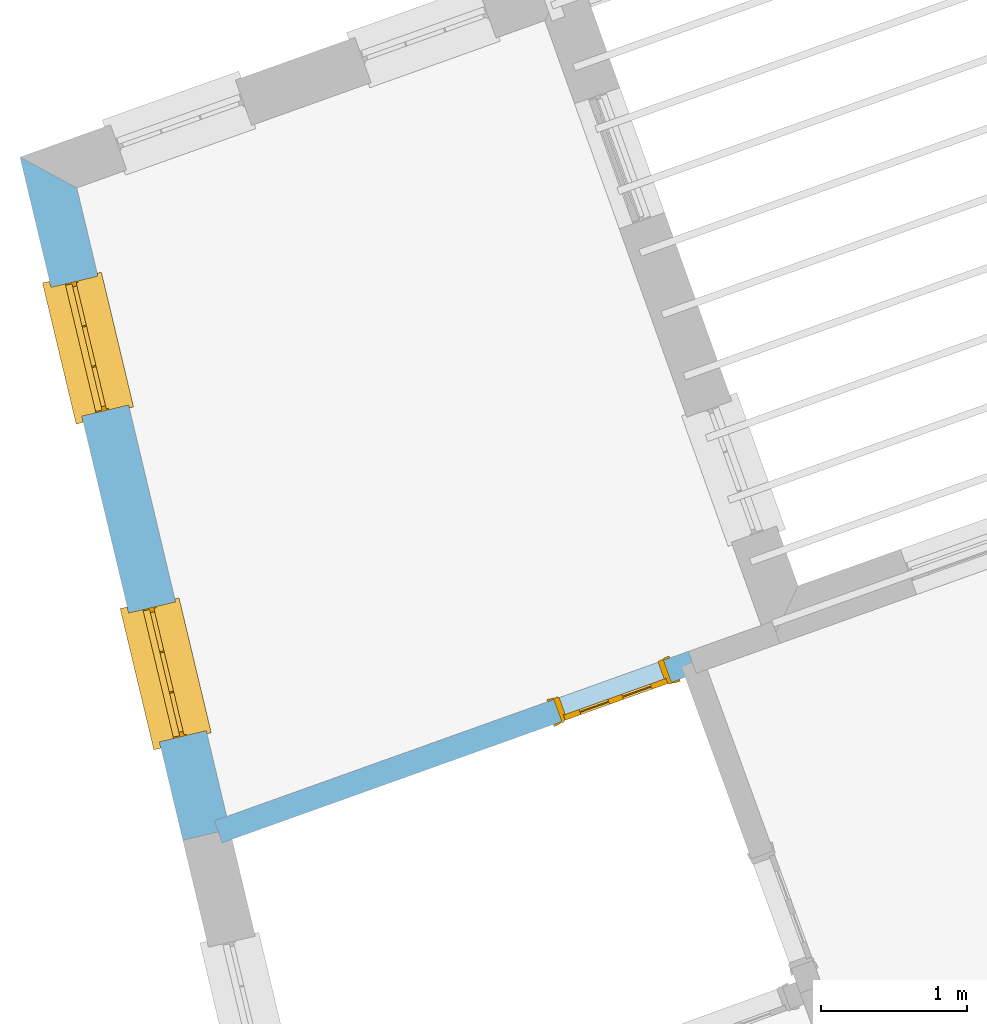
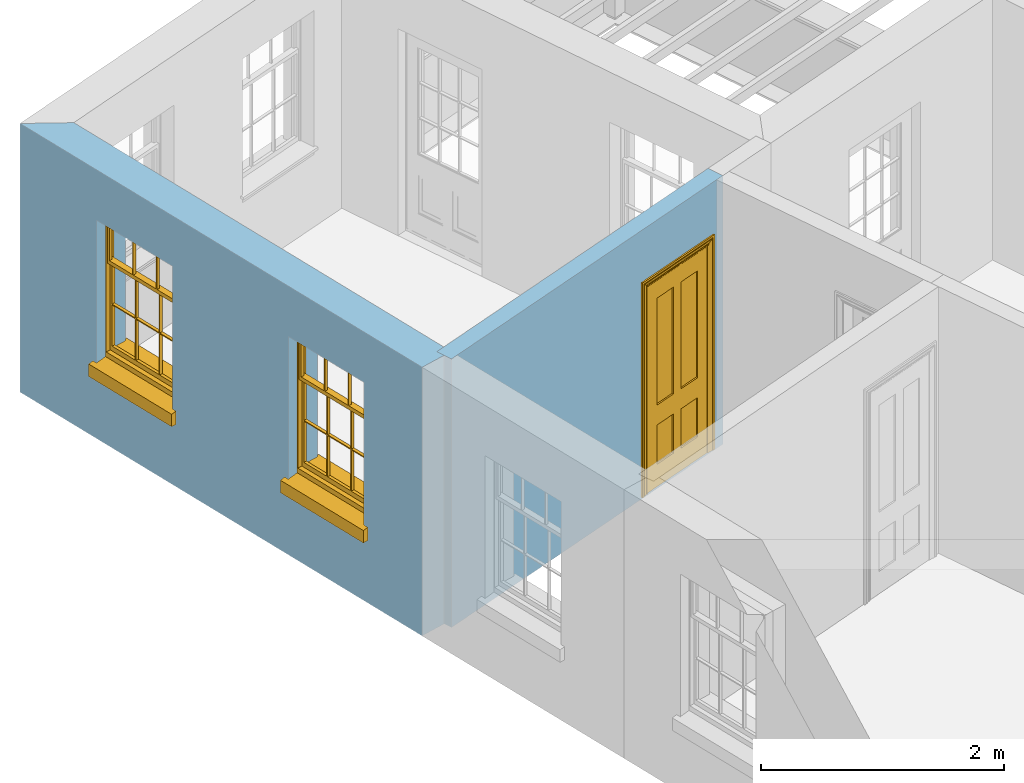
# One storey, part 8 of 12: 2 windows, 1 door, 3 openings, plus 2 elements that do not belong to this part.
"""IFC2X3 building model written with IfcOpenShell, lengths in metres."""

from ifc_helpers import new_model, si_unit, frame, origin, place, context, subcontext, project, spatial, polyline, outline, extrude, faceted_brep, material, layer, layer_set, layer_usage, element, fill, save


model = new_model("IFC2X3")

# Units and contexts
model_context = context("Model", 3, world=origin())
body_context = subcontext(model_context, "Body", "Model", "MODEL_VIEW")
ifc_project = project(units=[si_unit("PLANEANGLEUNIT", "RADIAN"), si_unit("MASSUNIT", "GRAM", prefix="KILO"), si_unit("FORCEUNIT", "NEWTON", prefix="KILO"), si_unit("LENGTHUNIT", "METRE")], contexts=[model_context])

# Site, building, storey
site_placement = place(None, origin())
site = spatial("IfcSite", under=ifc_project, at=site_placement, CompositionType="ELEMENT")
building_placement = place(None, origin())
building = spatial("IfcBuilding", under=site, at=building_placement, Name="Building plot-12", CompositionType="ELEMENT")
storey_placement = place(None, frame((0.0, 0.0, 6.45)))
storey = spatial("IfcBuildingStorey", under=building, at=storey_placement, Name="Floor 1", CompositionType="ELEMENT", Elevation=6.45)

# Wall, openings, windows
ifc_material_1 = material(Name="Masonry")
ifc_layer_1 = layer(ifc_material_1, 0.33, ventilated=False)
ifc_layer_set_1 = layer_set([ifc_layer_1], Name="My Wall")
ifc_layer_usage_1 = layer_usage(ifc_layer_set_1, "AXIS2", "NEGATIVE", 0.08)
wall_1_placement = place(storey_placement, origin())
wall_1 = element("IfcWallStandardCase", 1, at=wall_1_placement, inside=storey, material=ifc_layer_usage_1, Name="exterior", context=body_context, shape_type="SweptSolid", body=[
    extrude(outline(polyline([(53.1438565991735, 42.9766000900277), (52.7542538663581, 43.1877513545865), (53.8716114947725, 38.5019523700673), (54.1926114220858, 38.578496779823), (53.1438565991735, 42.9766000900277)])), origin(), (0.0, 0.0, 1.0), 2.7),
])
opening_1_placement = place(storey_placement, frame((0.0, 0.0, 0.75)))
opening_1 = element("IfcOpeningElement", 2, at=opening_1_placement, cuts=wall_1, Name="Opening", ObjectType="Opening", context=body_context, shape_type="SweptSolid", body=[
    extrude(outline(polyline([(52.9670336358641, 42.295428966013), (53.1781106445844, 41.4102473482703), (53.4991105718977, 41.486791758026), (53.2880335631774, 42.3719733757687), (52.9670336358641, 42.295428966013)])), origin(), (0.0, 0.0, 1.0), 1.445),
])
opening_2_placement = place(storey_placement, frame((0.0, 0.0, 0.75)))
opening_2 = element("IfcOpeningElement", 3, at=opening_2_placement, cuts=wall_1, Name="Opening", ObjectType="Opening", context=body_context, shape_type="SweptSolid", body=[
    extrude(outline(polyline([(53.4997265388962, 40.0615051079635), (53.7108035476165, 39.1763234902207), (54.0318034749299, 39.2528678999764), (53.8207264662095, 40.1380495177192), (53.4997265388962, 40.0615051079635)])), origin(), (0.0, 0.0, 1.0), 1.445),
])
window_1_placement = place(storey_placement, frame((53.2102153989802, 42.3534171552219, 0.75), z_axis=(0.0, 0.0, 1.0), x_axis=(0.211077008720331, -0.885181617742759, 0.0)))
window_1 = element("IfcWindow", 4, at=window_1_placement, inside=storey, Name="bedroom outside window", OverallHeight=1.445, OverallWidth=0.91, context=body_context, shape_type="Brep", held_by="IfcProductRepresentation", body=[
    faceted_brep([(0.876875, -0.105, 0.999097), (0.876875, -0.105, 1.411875), (0.9, -0.105, 1.435), (0.033125, -0.105, 1.411875), (0.033125, -0.105, 0.999097), (0.01, -0.105, 1.435), (0.033125, -0.135, 1.411875), (0.01, -0.135, 1.435), (0.033125, -0.135, 0.999097), (0.876875, -0.135, 1.411875), (0.876875, -0.135, 0.999097), (0.9, -0.135, 1.435), (0.033125, -0.105, 0.960972), (0.01, -0.105, 0.960972), (0.033125, -0.105, 0.548195), (0.876875, -0.105, 0.960972), (0.876875, -0.105, 0.548195), (0.9, -0.105, 0.960972), (0.876875, -0.105, 0.538195), (0.876875, -0.105, 0.125417), (0.9, -0.105, 0.077167), (0.033125, -0.105, 0.125417), (0.033125, -0.105, 0.538195), (0.01, -0.105, 0.077167), (0.9, -0.135, 0.960972), (0.01, -0.135, 0.960972), (-0.0425, -0.25, 0.01), (-0.0425, -0.3, 0.001667), (0.0, -0.25, 0.01), (0.9525, -0.25, 0.01), (0.91, -0.25, 0.01), (0.9525, -0.3, 0.001667), (-0.02, 0.08, 0.077167), (0.0, 0.08, 0.077167), (-0.02, 0.11, 0.077167), (0.0, -0.06, 0.077167), (0.01, -0.06, 0.077167), (0.91, -0.06, 0.077167), (0.91, 0.08, 0.077167), (0.9, -0.06, 0.077167), (0.93, 0.08, 0.077167), (0.93, 0.11, 0.077167), (0.01, -0.105, 0.999097), (0.01, -0.075, 0.999097), (0.9, -0.105, 0.999097), (0.9, -0.075, 0.999097), (0.876875, -0.075, 0.125417), (0.876875, -0.075, 0.538195), (0.9, -0.075, 0.077167), (0.876875, -0.075, 0.548195), (0.876875, -0.075, 0.960972), (0.033125, -0.075, 0.125417), (0.01, -0.075, 0.077167), (0.033125, -0.075, 0.538195), (0.033125, -0.075, 0.960972), (0.033125, -0.075, 0.548195), (-0.02, 0.08, 0.052167), (-0.02, 0.11, 0.052167), (0.93, 0.11, 0.052167), (0.93, 0.08, 0.052167), (0.91, 0.08, 0.052167), (0.0, 0.08, 0.052167), (0.91, -0.15, 0.026667), (0.0, -0.15, 0.026667), (-0.0425, -0.3, -0.123333), (0.9525, -0.3, -0.123333), (-0.0425, -0.25, -0.123333), (0.9525, -0.25, -0.123333), (0.01, -0.06, 1.435), (0.9, -0.06, 1.435), (0.0, -0.06, 1.445), (0.91, -0.06, 1.445), (0.01, -0.15, 0.077167), (0.9, -0.15, 0.077167), (0.592292, -0.105, 0.125417), (0.592292, -0.075, 0.125417), (0.317708, -0.075, 0.125417), (0.317708, -0.105, 0.125417), (0.592292, -0.105, 0.548195), (0.317708, -0.105, 0.548195), (0.317708, -0.105, 0.538195), (0.592292, -0.105, 0.538195), (0.592292, -0.075, 0.548195), (0.317708, -0.075, 0.548195), (0.602292, -0.075, 0.548195), (0.602292, -0.105, 0.548195), (0.317708, -0.075, 0.538195), (0.307708, -0.075, 0.125417), (0.307708, -0.075, 0.538195), (0.602292, -0.075, 0.538195), (0.602292, -0.075, 0.125417), (0.592292, -0.075, 0.538195), (0.307708, -0.075, 0.548195), (0.317708, -0.075, 0.960972), (0.307708, -0.075, 0.960972), (0.602292, -0.075, 0.960972), (0.592292, -0.075, 0.960972), (0.307708, -0.105, 0.538195), (0.307708, -0.105, 0.125417), (0.307708, -0.105, 0.548195), (0.307708, -0.105, 0.960972), (0.592292, -0.105, 0.960972), (0.317708, -0.105, 0.960972), (0.602292, -0.105, 0.960972), (0.602292, -0.105, 0.538195), (0.602292, -0.105, 0.125417), (0.317708, -0.135, 1.411875), (0.307708, -0.135, 1.411875), (0.307708, -0.135, 0.999097), (0.317708, -0.135, 0.999097), (0.602292, -0.135, 1.411875), (0.592292, -0.135, 1.411875), (0.592292, -0.135, 0.999097), (0.602292, -0.135, 0.999097), (0.317708, -0.105, 0.999097), (0.307708, -0.105, 0.999097), (0.307708, -0.105, 1.411875), (0.317708, -0.105, 1.411875), (0.602292, -0.105, 0.999097), (0.592292, -0.105, 0.999097), (0.592292, -0.105, 1.411875), (0.602292, -0.105, 1.411875), (0.91, -0.15, 1.445), (0.9, -0.15, 1.435), (0.01, -0.15, 1.435), (0.0, -0.15, 1.445), (0.91, -0.25, 0.0), (0.0, -0.25, 0.0), (0.91, 0.08, 0.0), (0.0, 0.08, 0.0)], [[[0, 1, 2]], [[3, 4, 5]], [[6, 7, 8]], [[9, 10, 11]], [[12, 13, 14]], [[15, 16, 17]], [[18, 19, 20]], [[21, 22, 23]], [[24, 15, 17]], [[13, 12, 25]], [[26, 27, 28]], [[29, 30, 31]], [[32, 33, 34]], [[35, 36, 33]], [[37, 38, 39]], [[40, 41, 38]], [[42, 4, 43]], [[44, 45, 0]], [[46, 47, 48]], [[49, 50, 45]], [[51, 52, 53]], [[54, 55, 43]], [[38, 33, 36, 39]], [[41, 34, 33, 38]], [[56, 32, 34, 57]], [[57, 34, 41, 58]], [[58, 41, 40, 59]], [[57, 58, 60, 61]], [[52, 48, 39, 36]], [[62, 63, 28, 30]], [[27, 31, 30, 28]], [[27, 64, 65, 31]], [[66, 67, 65, 64]], [[2, 5, 68, 69]], [[68, 70, 71, 69]], [[20, 23, 72, 73]], [[73, 72, 63, 62]], [[74, 75, 76, 77]], [[78, 79, 80, 81]], [[78, 82, 83, 79]], [[16, 49, 84, 85]], [[86, 76, 87, 88]], [[89, 90, 75, 91]], [[92, 88, 53, 55]], [[82, 91, 86, 83]], [[93, 83, 92, 94]], [[95, 84, 82, 96]], [[89, 84, 49, 47]], [[97, 88, 87, 98]], [[22, 53, 88, 97]], [[81, 91, 75, 74]], [[80, 86, 91, 81]], [[77, 76, 86, 80]], [[99, 92, 55, 14]], [[100, 94, 92, 99]], [[101, 96, 82, 78]], [[79, 83, 93, 102]], [[85, 84, 95, 103]], [[104, 89, 47, 18]], [[105, 90, 89, 104]], [[104, 18, 16, 85]], [[80, 97, 98, 77]], [[104, 81, 74, 105]], [[103, 101, 78, 85]], [[99, 14, 22, 97]], [[102, 100, 99, 79]], [[106, 107, 108, 109]], [[110, 111, 112, 113]], [[114, 115, 116, 117]], [[118, 119, 120, 121]], [[107, 116, 115, 108]], [[111, 120, 119, 112]], [[109, 114, 117, 106]], [[113, 118, 121, 110]], [[85, 78, 81, 104]], [[84, 89, 91, 82]], [[83, 86, 88, 92]], [[79, 99, 97, 80]], [[109, 112, 119, 114]], [[102, 93, 96, 101]], [[106, 117, 120, 111]], [[98, 87, 51, 21]], [[6, 3, 116, 107]], [[110, 121, 1, 9]], [[19, 46, 90, 105]], [[26, 66, 64, 27]], [[29, 31, 65, 67]], [[25, 24, 112, 109]], [[11, 7, 106, 111]], [[75, 48, 52, 76]], [[43, 45, 96, 93]], [[45, 43, 114, 119]], [[5, 2, 120, 117]], [[24, 25, 102, 101]], [[42, 5, 4]], [[2, 44, 0]], [[49, 45, 48, 47]], [[52, 43, 55, 53]], [[14, 13, 23, 22]], [[20, 17, 16, 18]], [[24, 11, 10]], [[25, 8, 7]], [[8, 4, 3, 6]], [[9, 1, 0, 10]], [[15, 50, 49, 16]], [[18, 47, 46, 19]], [[21, 51, 53, 22]], [[14, 55, 54, 12]], [[44, 2, 69, 45]], [[68, 5, 42, 43]], [[36, 35, 70, 68]], [[39, 69, 71, 37]], [[62, 122, 123, 73]], [[63, 72, 124, 125]], [[8, 108, 115, 4]], [[113, 10, 0, 118]], [[94, 100, 12, 54]], [[17, 20, 73, 24]], [[72, 23, 13, 25]], [[52, 36, 68, 43]], [[69, 39, 48, 45]], [[11, 24, 73, 123]], [[7, 124, 72, 25]], [[23, 77, 98]], [[98, 21, 23]], [[105, 74, 20]], [[20, 19, 105]], [[20, 74, 77, 23]], [[113, 112, 24]], [[24, 10, 113]], [[25, 109, 108]], [[108, 8, 25]], [[110, 9, 11]], [[11, 111, 110]], [[7, 6, 107]], [[107, 106, 7]], [[5, 117, 116]], [[116, 3, 5]], [[121, 120, 2]], [[2, 1, 121]], [[11, 123, 124, 7]], [[122, 125, 124, 123]], [[43, 93, 94]], [[94, 54, 43]], [[96, 45, 95]], [[50, 95, 45]], [[15, 103, 95, 50]], [[48, 75, 90]], [[90, 46, 48]], [[87, 76, 52]], [[52, 51, 87]], [[103, 15, 24]], [[24, 101, 103]], [[100, 102, 25]], [[25, 12, 100]], [[115, 114, 43]], [[43, 4, 115]], [[118, 0, 45]], [[45, 119, 118]], [[71, 70, 125, 122]], [[70, 35, 63, 125]], [[122, 62, 37, 71]], [[126, 67, 66, 127]], [[60, 58, 59]], [[38, 60, 59, 40]], [[61, 56, 57]], [[32, 56, 61, 33]], [[61, 60, 128, 129]], [[62, 60, 38, 37]], [[126, 128, 60, 62]], [[33, 61, 63, 35]], [[61, 129, 127, 63]], [[128, 126, 127, 129]], [[28, 127, 66, 26]], [[63, 127, 28]], [[29, 67, 126, 30]], [[30, 126, 62]]]),
])
fill(opening_1, window_1)
window_2_placement = place(storey_placement, frame((53.7429083020124, 40.1194932971724, 0.75), z_axis=(0.0, 0.0, 1.0), x_axis=(0.211077008720331, -0.885181617742759, 0.0)))
window_2 = element("IfcWindow", 5, at=window_2_placement, inside=storey, Name="bedroom outside window", OverallHeight=1.445, OverallWidth=0.91, context=body_context, shape_type="Brep", held_by="IfcProductRepresentation", body=[
    faceted_brep([(0.876875, -0.105, 0.999097), (0.876875, -0.105, 1.411875), (0.9, -0.105, 1.435), (0.033125, -0.105, 1.411875), (0.033125, -0.105, 0.999097), (0.01, -0.105, 1.435), (0.033125, -0.135, 1.411875), (0.01, -0.135, 1.435), (0.033125, -0.135, 0.999097), (0.876875, -0.135, 1.411875), (0.876875, -0.135, 0.999097), (0.9, -0.135, 1.435), (0.033125, -0.105, 0.960972), (0.01, -0.105, 0.960972), (0.033125, -0.105, 0.548195), (0.876875, -0.105, 0.960972), (0.876875, -0.105, 0.548195), (0.9, -0.105, 0.960972), (0.876875, -0.105, 0.538195), (0.876875, -0.105, 0.125417), (0.9, -0.105, 0.077167), (0.033125, -0.105, 0.125417), (0.033125, -0.105, 0.538195), (0.01, -0.105, 0.077167), (0.9, -0.135, 0.960972), (0.01, -0.135, 0.960972), (-0.0425, -0.25, 0.01), (-0.0425, -0.3, 0.001667), (0.0, -0.25, 0.01), (0.9525, -0.25, 0.01), (0.91, -0.25, 0.01), (0.9525, -0.3, 0.001667), (-0.02, 0.08, 0.077167), (0.0, 0.08, 0.077167), (-0.02, 0.11, 0.077167), (0.0, -0.06, 0.077167), (0.01, -0.06, 0.077167), (0.91, -0.06, 0.077167), (0.91, 0.08, 0.077167), (0.9, -0.06, 0.077167), (0.93, 0.08, 0.077167), (0.93, 0.11, 0.077167), (0.01, -0.105, 0.999097), (0.01, -0.075, 0.999097), (0.9, -0.105, 0.999097), (0.9, -0.075, 0.999097), (0.876875, -0.075, 0.125417), (0.876875, -0.075, 0.538195), (0.9, -0.075, 0.077167), (0.876875, -0.075, 0.548195), (0.876875, -0.075, 0.960972), (0.033125, -0.075, 0.125417), (0.01, -0.075, 0.077167), (0.033125, -0.075, 0.538195), (0.033125, -0.075, 0.960972), (0.033125, -0.075, 0.548195), (-0.02, 0.08, 0.052167), (-0.02, 0.11, 0.052167), (0.93, 0.11, 0.052167), (0.93, 0.08, 0.052167), (0.91, 0.08, 0.052167), (0.0, 0.08, 0.052167), (0.91, -0.15, 0.026667), (0.0, -0.15, 0.026667), (-0.0425, -0.3, -0.123333), (0.9525, -0.3, -0.123333), (-0.0425, -0.25, -0.123333), (0.9525, -0.25, -0.123333), (0.01, -0.06, 1.435), (0.9, -0.06, 1.435), (0.0, -0.06, 1.445), (0.91, -0.06, 1.445), (0.01, -0.15, 0.077167), (0.9, -0.15, 0.077167), (0.592292, -0.105, 0.125417), (0.592292, -0.075, 0.125417), (0.317708, -0.075, 0.125417), (0.317708, -0.105, 0.125417), (0.592292, -0.105, 0.548195), (0.317708, -0.105, 0.548195), (0.317708, -0.105, 0.538195), (0.592292, -0.105, 0.538195), (0.592292, -0.075, 0.548195), (0.317708, -0.075, 0.548195), (0.602292, -0.075, 0.548195), (0.602292, -0.105, 0.548195), (0.317708, -0.075, 0.538195), (0.307708, -0.075, 0.125417), (0.307708, -0.075, 0.538195), (0.602292, -0.075, 0.538195), (0.602292, -0.075, 0.125417), (0.592292, -0.075, 0.538195), (0.307708, -0.075, 0.548195), (0.317708, -0.075, 0.960972), (0.307708, -0.075, 0.960972), (0.602292, -0.075, 0.960972), (0.592292, -0.075, 0.960972), (0.307708, -0.105, 0.538195), (0.307708, -0.105, 0.125417), (0.307708, -0.105, 0.548195), (0.307708, -0.105, 0.960972), (0.592292, -0.105, 0.960972), (0.317708, -0.105, 0.960972), (0.602292, -0.105, 0.960972), (0.602292, -0.105, 0.538195), (0.602292, -0.105, 0.125417), (0.317708, -0.135, 1.411875), (0.307708, -0.135, 1.411875), (0.307708, -0.135, 0.999097), (0.317708, -0.135, 0.999097), (0.602292, -0.135, 1.411875), (0.592292, -0.135, 1.411875), (0.592292, -0.135, 0.999097), (0.602292, -0.135, 0.999097), (0.317708, -0.105, 0.999097), (0.307708, -0.105, 0.999097), (0.307708, -0.105, 1.411875), (0.317708, -0.105, 1.411875), (0.602292, -0.105, 0.999097), (0.592292, -0.105, 0.999097), (0.592292, -0.105, 1.411875), (0.602292, -0.105, 1.411875), (0.91, -0.15, 1.445), (0.9, -0.15, 1.435), (0.01, -0.15, 1.435), (0.0, -0.15, 1.445), (0.91, -0.25, 0.0), (0.0, -0.25, 0.0), (0.91, 0.08, 0.0), (0.0, 0.08, 0.0)], [[[0, 1, 2]], [[3, 4, 5]], [[6, 7, 8]], [[9, 10, 11]], [[12, 13, 14]], [[15, 16, 17]], [[18, 19, 20]], [[21, 22, 23]], [[24, 15, 17]], [[13, 12, 25]], [[26, 27, 28]], [[29, 30, 31]], [[32, 33, 34]], [[35, 36, 33]], [[37, 38, 39]], [[40, 41, 38]], [[42, 4, 43]], [[44, 45, 0]], [[46, 47, 48]], [[49, 50, 45]], [[51, 52, 53]], [[54, 55, 43]], [[38, 33, 36, 39]], [[41, 34, 33, 38]], [[56, 32, 34, 57]], [[57, 34, 41, 58]], [[58, 41, 40, 59]], [[57, 58, 60, 61]], [[52, 48, 39, 36]], [[62, 63, 28, 30]], [[27, 31, 30, 28]], [[27, 64, 65, 31]], [[66, 67, 65, 64]], [[2, 5, 68, 69]], [[68, 70, 71, 69]], [[20, 23, 72, 73]], [[73, 72, 63, 62]], [[74, 75, 76, 77]], [[78, 79, 80, 81]], [[78, 82, 83, 79]], [[16, 49, 84, 85]], [[86, 76, 87, 88]], [[89, 90, 75, 91]], [[92, 88, 53, 55]], [[82, 91, 86, 83]], [[93, 83, 92, 94]], [[95, 84, 82, 96]], [[89, 84, 49, 47]], [[97, 88, 87, 98]], [[22, 53, 88, 97]], [[81, 91, 75, 74]], [[80, 86, 91, 81]], [[77, 76, 86, 80]], [[99, 92, 55, 14]], [[100, 94, 92, 99]], [[101, 96, 82, 78]], [[79, 83, 93, 102]], [[85, 84, 95, 103]], [[104, 89, 47, 18]], [[105, 90, 89, 104]], [[104, 18, 16, 85]], [[80, 97, 98, 77]], [[104, 81, 74, 105]], [[103, 101, 78, 85]], [[99, 14, 22, 97]], [[102, 100, 99, 79]], [[106, 107, 108, 109]], [[110, 111, 112, 113]], [[114, 115, 116, 117]], [[118, 119, 120, 121]], [[107, 116, 115, 108]], [[111, 120, 119, 112]], [[109, 114, 117, 106]], [[113, 118, 121, 110]], [[85, 78, 81, 104]], [[84, 89, 91, 82]], [[83, 86, 88, 92]], [[79, 99, 97, 80]], [[109, 112, 119, 114]], [[102, 93, 96, 101]], [[106, 117, 120, 111]], [[98, 87, 51, 21]], [[6, 3, 116, 107]], [[110, 121, 1, 9]], [[19, 46, 90, 105]], [[26, 66, 64, 27]], [[29, 31, 65, 67]], [[25, 24, 112, 109]], [[11, 7, 106, 111]], [[75, 48, 52, 76]], [[43, 45, 96, 93]], [[45, 43, 114, 119]], [[5, 2, 120, 117]], [[24, 25, 102, 101]], [[42, 5, 4]], [[2, 44, 0]], [[49, 45, 48, 47]], [[52, 43, 55, 53]], [[14, 13, 23, 22]], [[20, 17, 16, 18]], [[24, 11, 10]], [[25, 8, 7]], [[8, 4, 3, 6]], [[9, 1, 0, 10]], [[15, 50, 49, 16]], [[18, 47, 46, 19]], [[21, 51, 53, 22]], [[14, 55, 54, 12]], [[44, 2, 69, 45]], [[68, 5, 42, 43]], [[36, 35, 70, 68]], [[39, 69, 71, 37]], [[62, 122, 123, 73]], [[63, 72, 124, 125]], [[8, 108, 115, 4]], [[113, 10, 0, 118]], [[94, 100, 12, 54]], [[17, 20, 73, 24]], [[72, 23, 13, 25]], [[52, 36, 68, 43]], [[69, 39, 48, 45]], [[11, 24, 73, 123]], [[7, 124, 72, 25]], [[23, 77, 98]], [[98, 21, 23]], [[105, 74, 20]], [[20, 19, 105]], [[20, 74, 77, 23]], [[113, 112, 24]], [[24, 10, 113]], [[25, 109, 108]], [[108, 8, 25]], [[110, 9, 11]], [[11, 111, 110]], [[7, 6, 107]], [[107, 106, 7]], [[5, 117, 116]], [[116, 3, 5]], [[121, 120, 2]], [[2, 1, 121]], [[11, 123, 124, 7]], [[122, 125, 124, 123]], [[43, 93, 94]], [[94, 54, 43]], [[96, 45, 95]], [[50, 95, 45]], [[15, 103, 95, 50]], [[48, 75, 90]], [[90, 46, 48]], [[87, 76, 52]], [[52, 51, 87]], [[103, 15, 24]], [[24, 101, 103]], [[100, 102, 25]], [[25, 12, 100]], [[115, 114, 43]], [[43, 4, 115]], [[118, 0, 45]], [[45, 119, 118]], [[71, 70, 125, 122]], [[70, 35, 63, 125]], [[122, 62, 37, 71]], [[126, 67, 66, 127]], [[60, 58, 59]], [[38, 60, 59, 40]], [[61, 56, 57]], [[32, 56, 61, 33]], [[61, 60, 128, 129]], [[62, 60, 38, 37]], [[126, 128, 60, 62]], [[33, 61, 63, 35]], [[61, 129, 127, 63]], [[128, 126, 127, 129]], [[28, 127, 66, 26]], [[63, 127, 28]], [[29, 67, 126, 30]], [[30, 126, 62]]]),
])
fill(opening_2, window_2)

# Wall, opening, door
ifc_material_2 = material(Name="Masonry")
ifc_layer_2 = layer(ifc_material_2, 0.16, ventilated=False)
ifc_layer_set_2 = layer_set([ifc_layer_2], Name="My Wall")
ifc_layer_usage_2 = layer_usage(ifc_layer_set_2, "AXIS2", "NEGATIVE", 0.08)
wall_2_placement = place(storey_placement, origin())
wall_2 = element("IfcWallStandardCase", 6, at=wall_2_placement, inside=storey, material=ifc_layer_usage_2, Name="interior", context=body_context, shape_type="SweptSolid", body=[
    extrude(outline(polyline([(57.3919994376429, 39.6468153550089), (57.3381283541499, 39.7974735986045), (54.0878577161421, 38.635269681074), (54.1417287996351, 38.4846114374784), (57.3919994376429, 39.6468153550089)])), origin(), (0.0, 0.0, 1.0), 2.7),
])
opening_3_placement = place(storey_placement, frame((0.0, 0.0, 0.0199999999999996)))
opening_3 = element("IfcOpeningElement", 7, at=opening_3_placement, cuts=wall_2, Name="Opening", ObjectType="Opening", context=body_context, shape_type="SweptSolid", body=[
    extrude(outline(polyline([(57.1686378301049, 39.7368686296748), (56.4153466121273, 39.4675132122098), (56.4692176956203, 39.3168549686143), (57.2225089135979, 39.5862103860793), (57.1686378301049, 39.7368686296748)])), origin(), (0.0, 0.0, 1.0), 2.1),
])
door_placement = place(storey_placement, frame((57.1955733718514, 39.6615395078771, 0.0199999999999996), z_axis=(0.0, 0.0, 1.0), x_axis=(-0.75329121797764, -0.269355417465036, 0.0)))
door = element("IfcDoor", 8, at=door_placement, inside=storey, Name="bedroom inside door", OverallHeight=2.1, OverallWidth=0.8, context=body_context, shape_type="Brep", held_by="IfcProductRepresentation", body=[
    faceted_brep([(0.773, 0.08, 1.895), (0.66, 0.08, 1.895), (0.66, 0.08, 2.073), (0.773, 0.08, 2.073), (0.773, 0.08, 0.82), (0.66, 0.08, 0.82), (0.45, 0.08, 1.895), (0.45, 0.08, 2.073), (0.773, 0.08, 0.62), (0.66, 0.08, 0.62), (0.66, 0.065, 0.82), (0.66, 0.065, 1.895), (0.45, 0.065, 1.895), (0.35, 0.08, 1.895), (0.35, 0.08, 2.073), (0.773, 0.08, 0.225), (0.66, 0.08, 0.225), (0.45, 0.08, 0.62), (0.45, 0.08, 0.82), (0.45, 0.065, 0.82), (0.35, 0.08, 0.82), (0.14, 0.08, 2.073), (0.14, 0.08, 1.895), (0.773, 0.08, 0.0), (0.66, 0.08, 0.0), (0.66, 0.065, 0.225), (0.66, 0.065, 0.62), (0.45, 0.065, 0.62), (0.35, 0.08, 0.62), (0.35, 0.065, 0.82), (0.35, 0.065, 1.895), (0.14, 0.065, 1.895), (0.027, 0.08, 2.073), (0.027, 0.08, 1.895), (0.773, 0.042, 0.0), (0.66, 0.042, 0.0), (0.45, 0.08, 0.0), (0.45, 0.08, 0.225), (0.45, 0.065, 0.225), (0.35, 0.08, 0.225), (0.14, 0.08, 0.82), (0.14, 0.08, 0.62), (0.14, 0.065, 0.82), (0.027, 0.08, 0.82), (0.773, 0.042, 0.225), (0.66, 0.042, 0.225), (0.45, 0.042, 0.0), (0.35, 0.08, 0.0), (0.35, 0.065, 0.225), (0.35, 0.065, 0.62), (0.14, 0.065, 0.62), (0.027, 0.08, 0.62), (0.773, 0.042, 0.62), (0.66, 0.042, 0.62), (0.45, 0.042, 0.225), (0.35, 0.042, 0.0), (0.14, 0.08, 0.225), (0.14, 0.08, 0.0), (0.14, 0.065, 0.225), (0.027, 0.08, 0.225), (0.773, 0.042, 0.82), (0.66, 0.042, 0.82), (0.66, 0.057, 0.62), (0.66, 0.057, 0.225), (0.45, 0.057, 0.225), (0.35, 0.042, 0.225), (0.14, 0.042, 0.0), (0.027, 0.08, 0.0), (0.773, 0.042, 1.895), (0.66, 0.042, 1.895), (0.45, 0.042, 0.62), (0.45, 0.042, 0.82), (0.45, 0.057, 0.62), (0.35, 0.042, 0.62), (0.14, 0.042, 0.225), (0.027, 0.042, 0.0), (0.773, 0.042, 2.073), (0.66, 0.042, 2.073), (0.66, 0.057, 1.895), (0.66, 0.057, 0.82), (0.45, 0.057, 0.82), (0.35, 0.042, 0.82), (0.35, 0.057, 0.62), (0.35, 0.057, 0.225), (0.14, 0.057, 0.225), (0.027, 0.042, 0.225), (0.45, 0.042, 1.895), (0.45, 0.042, 2.073), (0.45, 0.057, 1.895), (0.35, 0.042, 1.895), (0.14, 0.042, 0.82), (0.14, 0.042, 0.62), (0.14, 0.057, 0.62), (0.027, 0.042, 0.62), (0.35, 0.042, 2.073), (0.35, 0.057, 1.895), (0.35, 0.057, 0.82), (0.14, 0.057, 0.82), (0.027, 0.042, 0.82), (0.14, 0.042, 2.073), (0.14, 0.042, 1.895), (0.14, 0.057, 1.895), (0.027, 0.042, 1.895), (0.027, 0.042, 2.073), (0.02, 0.085, 0.0), (0.005, 0.09, 0.0), (0.005, 0.09, 2.095), (0.02, 0.085, 2.08), (0.02, 0.08, 0.0), (0.0, 0.085, 0.0), (0.0, 0.085, 2.1), (0.795, 0.09, 2.095), (0.78, 0.085, 2.08), (0.02, 0.08, 2.08), (0.0, 0.08, 0.0), (-0.032, 0.095, 0.0), (-0.032, 0.095, 2.132), (0.8, 0.085, 2.1), (0.795, 0.09, 0.0), (0.78, 0.085, 0.0), (0.78, 0.08, 2.08), (0.04, 0.04, 0.0), (0.025, 0.04, 0.0), (0.025, 0.04, 2.075), (0.04, 0.04, 2.06), (-0.04, 0.09, 0.0), (-0.04, 0.09, 2.14), (0.832, 0.095, 2.132), (0.8, 0.085, 0.0), (0.78, 0.08, 0.0), (0.8, 0.08, 0.0), (0.86, 0.08, 0.0), (0.86, 0.08, 2.16), (0.8, 0.08, 2.1), (-0.06, 0.08, 2.16), (0.0, 0.08, 2.1), (-0.06, 0.08, 0.0), (-0.04, 0.095, 0.0), (-0.04, 0.095, 2.14), (0.84, 0.09, 2.14), (0.832, 0.095, 0.0), (0.84, 0.09, 0.0), (0.86, 0.095, 0.0), (0.86, 0.095, 2.16), (-0.06, 0.095, 2.16), (-0.06, 0.095, 0.0), (0.84, 0.095, 0.0), (0.84, 0.095, 2.14), (-0.025, -0.095, 0.0), (-0.025, -0.09, 0.0), (-0.025, -0.09, 2.125), (-0.025, -0.095, 2.125), (-0.017, -0.095, 0.0), (-0.017, -0.095, 2.117), (0.825, -0.09, 2.125), (0.825, -0.095, 2.125), (0.825, -0.095, 0.0), (0.845, -0.095, 0.0), (-0.045, -0.095, 2.145), (-0.045, -0.095, 0.0), (0.845, -0.095, 2.145), (0.015, -0.085, 0.0), (0.015, -0.085, 2.085), (0.817, -0.095, 2.117), (0.825, -0.09, 0.0), (0.845, -0.08, 0.0), (0.845, -0.08, 2.145), (-0.045, -0.08, 2.145), (-0.045, -0.08, 0.0), (0.02, -0.09, 0.0), (0.02, -0.09, 2.08), (0.785, -0.085, 2.085), (0.817, -0.095, 0.0), (0.8, -0.08, 0.0), (0.8, -0.08, 2.1), (0.0, -0.08, 2.1), (0.0, -0.08, 0.0), (0.035, -0.085, 0.0), (0.035, -0.085, 2.065), (0.78, -0.09, 2.08), (0.785, -0.085, 0.0), (0.775, 0.04, 2.075), (0.76, 0.04, 2.06), (0.035, -0.08, 2.065), (0.035, -0.08, 0.0), (0.765, -0.085, 2.065), (0.78, -0.09, 0.0), (0.765, -0.08, 0.0), (0.765, -0.08, 2.065), (0.765, -0.085, 0.0), (0.04, -0.08, 2.06), (0.04, -0.08, 0.0), (0.76, -0.08, 2.06), (0.76, -0.08, 0.0), (0.76, 0.04, 0.0), (0.775, 0.04, 0.0), (0.025, 0.08, 0.0), (0.025, 0.08, 2.075), (0.775, 0.08, 0.0), (0.775, 0.08, 2.075)], [[[0, 1, 2, 3]], [[1, 0, 4, 5]], [[1, 6, 7, 2]], [[8, 9, 5, 4]], [[1, 5, 10, 11]], [[6, 1, 11, 12]], [[6, 13, 14, 7]], [[15, 16, 9, 8]], [[9, 17, 18, 5]], [[5, 18, 19, 10]], [[10, 19, 12, 11]], [[18, 6, 12, 19]], [[18, 20, 13, 6]], [[21, 14, 13, 22]], [[23, 24, 16, 15]], [[9, 16, 25, 26]], [[17, 9, 26, 27]], [[17, 28, 20, 18]], [[13, 20, 29, 30]], [[22, 13, 30, 31]], [[32, 21, 22, 33]], [[34, 35, 24, 23]], [[24, 36, 37, 16]], [[16, 37, 38, 25]], [[25, 38, 27, 26]], [[37, 17, 27, 38]], [[37, 39, 28, 17]], [[40, 20, 28, 41]], [[20, 40, 42, 29]], [[31, 30, 29, 42]], [[40, 22, 31, 42]], [[33, 22, 40, 43]], [[35, 34, 44, 45]], [[35, 46, 36, 24]], [[36, 47, 39, 37]], [[28, 39, 48, 49]], [[41, 28, 49, 50]], [[43, 40, 41, 51]], [[45, 44, 52, 53]], [[46, 35, 45, 54]], [[46, 55, 47, 36]], [[56, 39, 47, 57]], [[39, 56, 58, 48]], [[50, 49, 48, 58]], [[56, 41, 50, 58]], [[51, 41, 56, 59]], [[53, 52, 60, 61]], [[45, 53, 62, 63]], [[54, 45, 63, 64]], [[55, 46, 54, 65]], [[55, 66, 57, 47]], [[59, 56, 57, 67]], [[61, 60, 68, 69]], [[70, 53, 61, 71]], [[53, 70, 72, 62]], [[72, 64, 63, 62]], [[70, 54, 64, 72]], [[65, 54, 70, 73]], [[65, 74, 66, 55]], [[67, 57, 66, 75]], [[69, 68, 76, 77]], [[61, 69, 78, 79]], [[71, 61, 79, 80]], [[73, 70, 71, 81]], [[65, 73, 82, 83]], [[74, 65, 83, 84]], [[74, 85, 75, 66]], [[86, 69, 77, 87]], [[69, 86, 88, 78]], [[88, 80, 79, 78]], [[86, 71, 80, 88]], [[81, 71, 86, 89]], [[73, 81, 90, 91]], [[73, 91, 92, 82]], [[83, 82, 92, 84]], [[91, 74, 84, 92]], [[91, 93, 85, 74]], [[89, 86, 87, 94]], [[81, 89, 95, 96]], [[90, 81, 96, 97]], [[90, 98, 93, 91]], [[94, 99, 100, 89]], [[89, 100, 101, 95]], [[101, 97, 96, 95]], [[100, 90, 97, 101]], [[100, 102, 98, 90]], [[99, 103, 102, 100]], [[32, 103, 99, 21]], [[102, 103, 32, 33]], [[98, 102, 33, 43]], [[21, 99, 94, 14]], [[94, 87, 7, 14]], [[7, 87, 77, 2]], [[76, 3, 2, 77]], [[43, 51, 93, 98]], [[51, 59, 85, 93]], [[67, 75, 85, 59]], [[34, 23, 15, 44]], [[44, 15, 8, 52]], [[52, 8, 4, 60]], [[0, 68, 60, 4]], [[0, 3, 76, 68]], [[104, 105, 106, 107]], [[104, 108, 109, 105]], [[105, 109, 110, 106]], [[107, 106, 111, 112]], [[107, 113, 108, 104]], [[114, 109, 108]], [[109, 115, 116, 110]], [[106, 110, 117, 111]], [[112, 111, 118, 119]], [[113, 107, 112, 120]], [[121, 122, 123, 124]], [[115, 109, 114, 125]], [[115, 125, 126, 116]], [[110, 116, 127, 117]], [[111, 117, 128, 118]], [[118, 128, 129, 119]], [[120, 112, 119, 129]], [[130, 129, 128]], [[130, 131, 132, 133]], [[133, 132, 134, 135]], [[135, 134, 136, 114]], [[136, 125, 114]], [[125, 137, 138, 126]], [[116, 126, 139, 127]], [[117, 127, 140, 128]], [[141, 130, 128, 140]], [[131, 130, 141]], [[131, 142, 143, 132]], [[132, 143, 144, 134]], [[134, 144, 145, 136]], [[137, 125, 136, 145]], [[143, 142, 146]], [[143, 146, 147]], [[137, 145, 144]], [[143, 147, 138]], [[138, 137, 144]], [[143, 138, 144]], [[126, 138, 147, 139]], [[127, 139, 141, 140]], [[142, 131, 141, 146]], [[139, 147, 146, 141]], [[148, 149, 150, 151]], [[149, 152, 153, 150]], [[151, 150, 154, 155]], [[155, 156, 157]], [[158, 159, 148]], [[158, 148, 151]], [[155, 157, 160]], [[158, 151, 155]], [[155, 160, 158]], [[152, 161, 162, 153]], [[150, 153, 163, 154]], [[155, 154, 164, 156]], [[156, 164, 165, 157]], [[157, 165, 166, 160]], [[160, 166, 167, 158]], [[158, 167, 168, 159]], [[161, 169, 170, 162]], [[153, 162, 171, 163]], [[154, 163, 172, 164]], [[165, 164, 173]], [[165, 173, 174, 166]], [[166, 174, 175, 167]], [[167, 175, 176, 168]], [[169, 177, 178, 170]], [[162, 170, 179, 171]], [[163, 171, 180, 172]], [[172, 180, 173, 164]], [[124, 123, 181, 182]], [[183, 178, 177, 184]], [[170, 178, 185, 179]], [[171, 179, 186, 180]], [[187, 173, 180]], [[185, 188, 187, 189]], [[188, 185, 178, 183]], [[179, 185, 189, 186]], [[189, 187, 180, 186]], [[190, 183, 184, 191]], [[192, 188, 183, 190]], [[191, 184, 122, 121]], [[124, 190, 191, 121]], [[193, 187, 188, 192]], [[182, 192, 190, 124]], [[184, 176, 122]], [[194, 195, 187, 193]], [[192, 182, 194, 193]], [[161, 176, 184]], [[114, 108, 122, 176]], [[173, 187, 195]], [[152, 149, 176, 161]], [[169, 161, 184, 177]], [[196, 122, 108]], [[176, 175, 135, 114]], [[173, 195, 129, 130]], [[176, 149, 168]], [[123, 122, 196, 197]], [[196, 108, 113, 197]], [[175, 174, 133, 135]], [[198, 129, 195]], [[133, 174, 173, 130]], [[159, 168, 149, 148]], [[181, 123, 197, 199]], [[197, 113, 120, 199]], [[199, 120, 129, 198]], [[195, 181, 199, 198]], [[195, 194, 182, 181]]]),
])
fill(opening_3, door)

save(model, "model.ifc")
